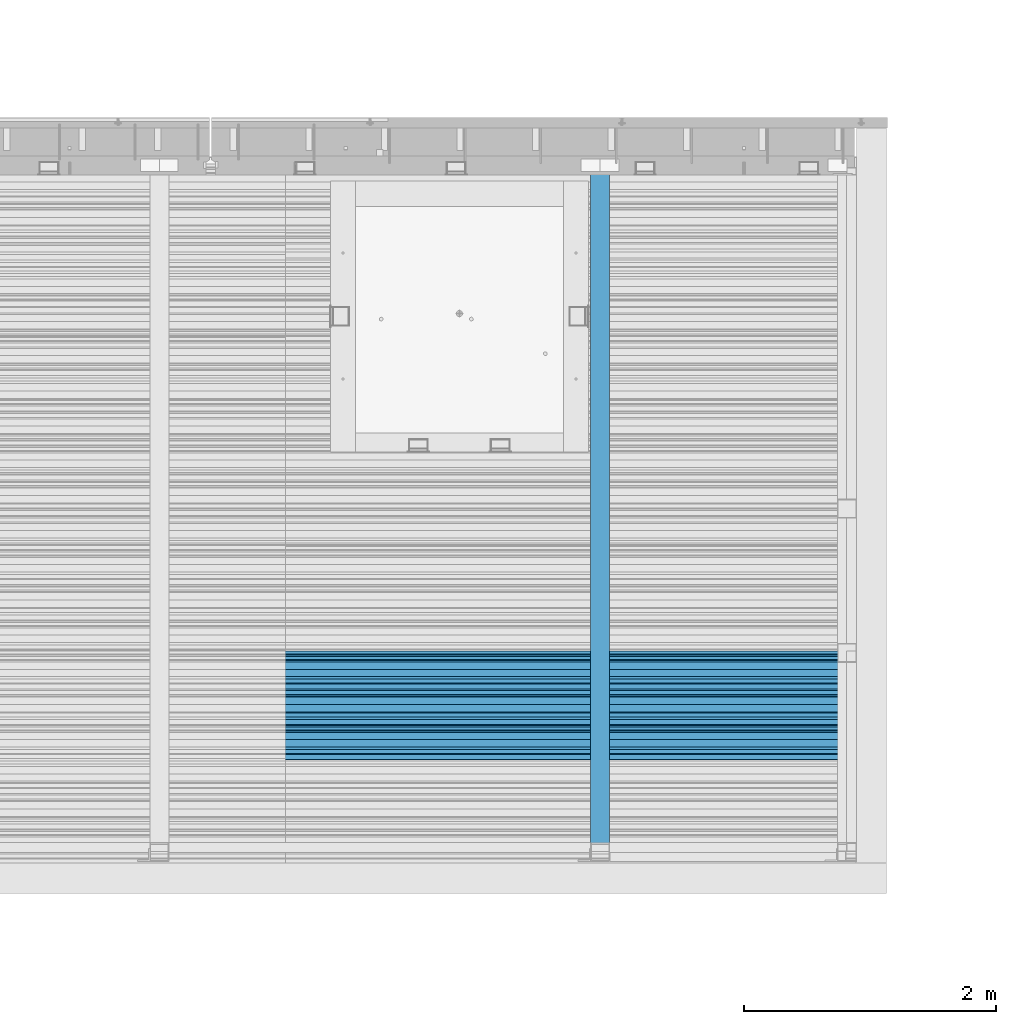
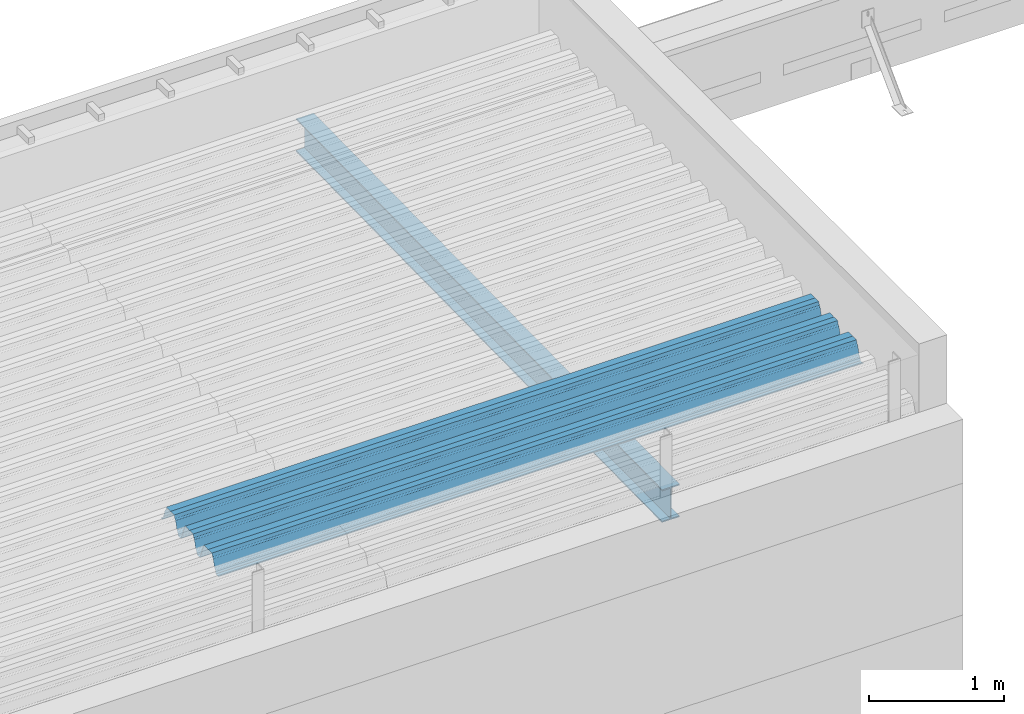
# One storey, part 37 of 153: 2 beams, 2 elements without a shape of their own.
"""IFC2X3 building model written with IfcOpenShell, lengths in millimetres."""

from ifc_helpers import new_model, si_unit, frame, origin_with_axes, place, context, subcontext, project, spatial, faceted_brep, material, type_object, element, aggregate, save


model = new_model("IFC2X3")

# Units and contexts
model_context = context("Model", 3, precision=1e-05, world=origin_with_axes())
body_context = subcontext(model_context, "Body", "Model", "MODEL_VIEW")
ifc_project = project(units=[si_unit("LENGTHUNIT", "METRE", prefix="MILLI"), si_unit("AREAUNIT", "SQUARE_METRE"), si_unit("VOLUMEUNIT", "CUBIC_METRE"), si_unit("MASSUNIT", "GRAM", prefix="KILO"), si_unit("TIMEUNIT", "SECOND"), si_unit("PLANEANGLEUNIT", "RADIAN"), si_unit("SOLIDANGLEUNIT", "STERADIAN"), si_unit("THERMODYNAMICTEMPERATUREUNIT", "DEGREE_CELSIUS"), si_unit("LUMINOUSINTENSITYUNIT", "LUMEN")], contexts=[model_context])

# Site, building, storey
site_placement = place(None, origin_with_axes())
site = spatial("IfcSite", under=ifc_project, at=site_placement, CompositionType="ELEMENT")
building_placement = place(site_placement, origin_with_axes())
building = spatial("IfcBuilding", under=site, at=building_placement, CompositionType="ELEMENT")
storey_placement = place(building_placement, origin_with_axes())
storey = spatial("IfcBuildingStorey", under=building, at=storey_placement, Name="8", CompositionType="ELEMENT", Elevation=0.0)

# Assembly, beam
assembly_1_placement = place(storey_placement, origin_with_axes())
assembly_1 = element("IfcElementAssembly", 1, at=assembly_1_placement, inside=storey, Name="Steel Assembly", AssemblyPlace="NOTDEFINED", PredefinedType="RIGID_FRAME")
ifc_material = material(Name="STEEL/S355J2")
beam_type_1 = type_object("IfcBeamType", Name="IPE300", PredefinedType="NOTDEFINED")
beam_1_placement = place(assembly_1_placement, frame((19752.0, 15128.0908589909, 105518.668698015), z_axis=(0.0, -0.0124990270013869, 0.999921884110963), x_axis=(0.0, 0.999921884110963, 0.0124990270013883)))
beam_1 = element("IfcBeam", 2, at=beam_1_placement, type_object=beam_type_1, material=ifc_material, ObjectType="IPE300", context=body_context, shape_type="Brep", body=[
    faceted_brep([(3.63797880709171e-12, 75.0, -149.999999999985), (0.0, 75.0, -139.300000189993), (5440.87494889885, 75.0, -139.300000189993), (5440.87494889886, 75.0, -150.0), (0.0, 3.5499999525, -139.300000189993), (5440.87494889885, 3.5499999525, -139.300000189993), (0.0, 3.5499999525, 139.300000190022), (5440.87494889885, 3.5499999525, 139.300000190022), (0.0, 75.0, 139.300000190022), (5440.87494889885, 75.0, 139.300000190022), (3.63797880709171e-12, 75.0, 150.0), (5440.87494889885, 75.0, 150.0), (3.63797880709171e-12, -75.0, 150.0), (5440.87494889885, -75.0, 150.0), (0.0, -75.0, 139.300000190022), (5440.87494889885, -75.0, 139.300000190022), (0.0, -3.5499999525, 139.300000190022), (5440.87494889885, -3.5499999525, 139.300000190022), (0.0, -3.5499999525, -139.300000189993), (5440.87494889885, -3.5499999525, -139.300000189993), (0.0, -75.0, -139.300000189993), (5440.87494889885, -75.0, -139.300000189993), (3.63797880709171e-12, -75.0, -149.999999999985), (5440.87494889886, -75.0, -150.0)], [[[0, 1, 2, 3]], [[1, 4, 5, 2]], [[4, 6, 7, 5]], [[6, 8, 9, 7]], [[8, 10, 11, 9]], [[10, 12, 13, 11]], [[12, 14, 15, 13]], [[14, 16, 17, 15]], [[16, 18, 19, 17]], [[18, 20, 21, 19]], [[20, 22, 23, 21]], [[22, 0, 3, 23]], [[5, 7, 9, 11, 13, 15, 17, 19, 21, 23, 3, 2]], [[22, 20, 18, 16, 14, 12, 10, 8, 6, 4, 1, 0]]]),
])
aggregate(assembly_1, [beam_1])

assembly_2_placement = place(storey_placement, origin_with_axes())
assembly_2 = element("IfcElementAssembly", 3, at=assembly_2_placement, inside=storey, Name="Steel Assembly", AssemblyPlace="NOTDEFINED", PredefinedType="RIGID_FRAME")
beam_type_2 = type_object("IfcBeamType", Name="W", PredefinedType="NOTDEFINED")
beam_2_placement = place(assembly_2_placement, frame((21782.0, 16215.1442180648, 105760.274680667), z_axis=(0.0, -0.0124990270013869, 0.999921884110963), x_axis=(-1.0, 3.00000001838171e-08, 0.0)))
beam_2 = element("IfcBeam", 4, at=beam_2_placement, type_object=beam_type_2, material=ifc_material, ObjectType="W", context=body_context, shape_type="Brep", body=[
    faceted_brep([(0.0, -412.839996337891, -77.0100021362159), (0.0, -409.160003662109, -77.0100021362014), (5530.0, -409.160003662109, -77.0100021362014), (5530.0, -412.839996337891, -77.0100021362159), (0.0, -408.070007324222, -73.4800033569045), (5530.0, -408.070007324222, -73.4800033569045), (0.0, -400.339996337894, -48.0600013732619), (5530.0, -400.339996337894, -48.0600013732619), (0.0, -399.459991455082, -46.5600013732619), (5530.0, -399.459991455082, -46.5600013732619), (0.0, -390.329986572269, -36.5499992370314), (5530.0, -390.329986572269, -36.5499992370314), (0.0, -389.19000244141, -34.6300010680861), (5530.0, -389.19000244141, -34.6300010680861), (0.0, -367.820007324222, 35.3400001526024), (5530.0, -367.820007324222, 35.3400001526024), (0.0, -366.989990234379, 36.8499984741502), (5530.0, -366.989990234379, 36.8499984741502), (0.0, -357.809997558597, 46.8600006103807), (5530.0, -357.809997558597, 46.8600006103807), (0.0, -356.720001220707, 48.7700004577782), (5530.0, -356.720001220707, 48.7700004577782), (0.0, -349.309997558594, 73.1500015258935), (5530.0, -349.309997558594, 73.1500015258935), (0.0, -347.850006103516, 75.2300033569481), (5530.0, -347.850006103516, 75.2300033569481), (0.0, -345.470001220707, 76.010002136245), (5530.0, -345.470001220707, 76.010002136245), (0.0, -305.480010986332, 76.010002136245), (5530.0, -305.480010986332, 76.010002136245), (0.0, -304.279998779301, 75.8000030517578), (5530.0, -304.279998779301, 75.8000030517578), (0.0, -291.679992675785, 71.6999969482567), (5530.0, -291.679992675785, 71.6999969482567), (0.0, -290.179992675789, 71.2300033569481), (5530.0, -290.179992675789, 71.2300033569481), (0.0, -288.720001220707, 71.6999969482567), (5530.0, -288.720001220707, 71.6999969482567), (0.0, -276.119995117191, 75.8000030517869), (5530.0, -276.119995117191, 75.8000030517869), (0.0, -274.929992675785, 76.010002136245), (5530.0, -274.929992675785, 76.010002136245), (0.0, -234.94000244141, 76.010002136245), (5530.0, -234.94000244141, 76.010002136245), (0.0, -232.550003051758, 75.2300033569627), (5530.0, -232.550003051758, 75.2300033569627), (0.0, -231.100006103519, 73.1500015258935), (5530.0, -231.100006103519, 73.1500015258935), (0.0, -223.679992675785, 48.7700004577782), (5530.0, -223.679992675785, 48.7700004577782), (0.0, -222.589996337894, 46.8600006103661), (5530.0, -222.589996337894, 46.8600006103661), (0.0, -213.410003662113, 36.8499984741502), (5530.0, -213.410003662113, 36.8499984741502), (0.0, -212.529998779301, 35.3400001526024), (5530.0, -212.529998779301, 35.3400001526024), (0.0, -191.160003662109, -34.6300010681007), (5530.0, -191.160003662109, -34.6300010681007), (0.0, -190.070007324222, -36.5499992370605), (5530.0, -190.070007324222, -36.5499992370605), (0.0, -180.940002441406, -46.560001373291), (5530.0, -180.940002441406, -46.560001373291), (0.0, -180.059997558597, -48.0600013732619), (5530.0, -180.059997558597, -48.0600013732619), (0.0, -172.330001831055, -73.480003356919), (5530.0, -172.330001831055, -73.480003356919), (0.0, -171.240005493168, -77.0100021362159), (5530.0, -171.240005493168, -77.0100021362159), (0.0, -129.330001831062, -77.0100021362014), (5530.0, -129.330001831062, -77.0100021362014), (0.0, -128.300003051761, -73.480003356919), (5530.0, -128.300003051761, -73.480003356919), (0.0, -120.51999664307, -48.0600013732765), (5530.0, -120.51999664307, -48.0600013732765), (0.0, -119.629997253418, -46.5600013732765), (5530.0, -119.629997253418, -46.5600013732765), (0.0, -110.500000000004, -36.5499992370314), (5530.0, -110.500000000004, -36.5499992370314), (0.0, -109.419998168949, -34.6300010680861), (5530.0, -109.419998168949, -34.6300010680861), (0.0, -88.0500030517615, 35.3400001526024), (5530.0, -88.0500030517615, 35.3400001526024), (0.0, -87.160003662113, 36.8499984741356), (5530.0, -87.160003662113, 36.8499984741356), (0.0, -78.0400009155273, 46.8600006103807), (5530.0, -78.0400009155273, 46.8600006103807), (0.0, -76.8899993896557, 48.7700004577782), (5530.0, -76.8899993896557, 48.7700004577782), (0.0, -69.4800033569336, 73.1500015258935), (5530.0, -69.4800033569336, 73.1500015258935), (0.0, -68.0299987793042, 75.2300033569336), (5530.0, -68.0299987793042, 75.2300033569336), (0.0, -65.6399993896521, 76.010002136245), (5530.0, -65.6399993896521, 76.010002136245), (0.0, -25.6499996185375, 76.0100021362596), (5530.0, -25.6499996185375, 76.0100021362596), (0.0, -24.5100002288891, 75.8000030517724), (5530.0, -24.5100002288891, 75.8000030517724), (0.0, -11.8500003814697, 71.6999969482567), (5530.0, -11.8500003814697, 71.6999969482567), (0.0, -10.3999996185339, 71.2300033569481), (5530.0, -10.3999996185339, 71.2300033569481), (0.0, -8.89999961853391, 71.6999969482567), (5530.0, -8.89999961853391, 71.6999969482567), (0.0, 3.71000003814333, 75.8000030517724), (5530.0, 3.71000003814333, 75.8000030517724), (0.0, 4.90000009536379, 76.0100021362596), (5530.0, 4.90000009536379, 76.0100021362596), (0.0, 44.8899993896484, 76.010002136245), (5530.0, 44.8899993896484, 76.010002136245), (0.0, 47.2799987792932, 75.2300033569481), (5530.0, 47.2799987792932, 75.2300033569481), (0.0, 48.6800003051721, 73.1500015258935), (5530.0, 48.6800003051721, 73.1500015258935), (0.0, 56.1500015258753, 48.7700004577782), (5530.0, 56.1500015258753, 48.7700004577782), (0.0, 57.2400016784632, 46.8600006103807), (5530.0, 57.2400016784632, 46.8600006103807), (0.0, 66.3700027465784, 36.8499984741211), (5530.0, 66.3700027465784, 36.8499984741211), (0.0, 67.2499999999964, 35.3400001526024), (5530.0, 67.2499999999964, 35.3400001526024), (0.0, 88.6200027465748, -34.6300010681007), (5530.0, 88.6200027465748, -34.6300010681007), (0.0, 89.709999084469, -36.549999237046), (5530.0, 89.709999084469, -36.549999237046), (0.0, 98.8899993896412, -46.5600013732765), (5530.0, 98.8899993896412, -46.5600013732765), (0.0, 99.7699966430628, -48.0600013732765), (5530.0, 99.7699966430628, -48.0600013732765), (0.0, 107.499999999996, -73.4800033569336), (5530.0, 107.499999999996, -73.4800033569336), (0.0, 108.589996337887, -77.0100021362014), (5530.0, 108.589996337887, -77.0100021362014), (0.0, 112.269996643063, -77.0100021362159), (5530.0, 112.269996643063, -77.0100021362159), (0.0, 146.759994506836, -77.0100021362159), (5530.0, 146.759994506836, -77.0100021362159), (0.0, 150.440002441403, -77.0100021362159), (5530.0, 150.440002441403, -77.0100021362159), (0.0, 151.529998779297, -73.480003356919), (5530.0, 151.529998779297, -73.480003356919), (0.0, 159.30999755859, -48.0600013732765), (5530.0, 159.30999755859, -48.0600013732765), (0.0, 160.190002441406, -46.5600013732619), (5530.0, 160.190002441406, -46.5600013732619), (0.0, 169.320007324215, -36.549999237046), (5530.0, 169.320007324215, -36.549999237046), (0.0, 170.410003662106, -34.6300010680861), (5530.0, 170.410003662106, -34.6300010680861), (0.0, 191.779998779293, 35.3400001526024), (5530.0, 191.779998779293, 35.3400001526024), (0.0, 192.660003662109, 36.8499984741502), (5530.0, 192.660003662109, 36.8499984741502), (0.0, 201.789993286129, 46.8600006103661), (5530.0, 201.789993286129, 46.8600006103661), (0.0, 202.880004882809, 48.7700004577637), (5530.0, 202.880004882809, 48.7700004577637), (0.0, 210.350006103512, 73.150001525908), (5530.0, 210.350006103512, 73.150001525908), (0.0, 211.800003051754, 75.2300033569481), (5530.0, 211.800003051754, 75.2300033569481), (0.0, 214.190002441406, 76.010002136245), (5530.0, 214.190002441406, 76.010002136245), (0.0, 254.179992675778, 76.010002136245), (5530.0, 254.179992675778, 76.010002136245), (0.0, 255.320007324215, 75.8000030517869), (5530.0, 255.320007324215, 75.8000030517869), (0.0, 267.980010986324, 71.6999969482713), (5530.0, 267.980010986324, 71.6999969482713), (0.0, 269.429992675778, 71.2300033569481), (5530.0, 269.429992675778, 71.2300033569481), (0.0, 270.880004882809, 71.6999969482567), (5530.0, 270.880004882809, 71.6999969482567), (0.0, 283.540008544918, 75.8000030517869), (5530.0, 283.540008544918, 75.8000030517869), (0.0, 284.679992675778, 76.010002136245), (5530.0, 284.679992675778, 76.010002136245), (0.0, 324.670013427731, 76.010002136245), (5530.0, 324.670013427731, 76.010002136245), (0.0, 327.049987792969, 75.2300033569627), (5530.0, 327.049987792969, 75.2300033569627), (0.0, 328.510009765625, 73.1500015258789), (5530.0, 328.510009765625, 73.1500015258789), (0.0, 335.980010986324, 48.7700004577782), (5530.0, 335.980010986324, 48.7700004577782), (0.0, 337.05999755859, 46.8600006103661), (5530.0, 337.05999755859, 46.8600006103661), (0.0, 346.190002441399, 36.8499984741356), (5530.0, 346.190002441399, 36.8499984741356), (0.0, 347.079986572266, 35.3400001526024), (5530.0, 347.079986572266, 35.3400001526024), (0.0, 368.450012207028, -34.6300010680861), (5530.0, 368.450012207028, -34.6300010680861), (0.0, 369.529998779293, -36.5499992370314), (5530.0, 369.529998779293, -36.5499992370314), (0.0, 378.660003662106, -46.5600013732619), (5530.0, 378.660003662106, -46.5600013732619), (0.0, 379.540008544918, -48.0600013732619), (5530.0, 379.540008544918, -48.0600013732619), (0.0, 387.329986572262, -73.480003356919), (5530.0, 387.329986572262, -73.480003356919), (0.0, 388.410003662109, -77.0100021362159), (5530.0, 388.410003662109, -77.0100021362159), (0.0, 392.100006103512, -77.0100021362159), (5530.0, 392.100006103512, -77.0100021362159), (0.0, 426.589996337887, -77.0100021362159), (5530.0, 426.589996337887, -77.0100021362159), (0.0, 430.269989013668, -77.0100021362159), (5530.0, 430.269989013668, -77.0100021362159), (0.0, 431.359985351559, -73.4800033569045), (5530.0, 431.359985351559, -73.4800033569045), (0.0, 433.179992675778, -67.5699996948097), (5530.0, 433.179992675778, -67.5699996948097), (0.0, 432.220001220699, -67.2699966430373), (5530.0, 432.220001220699, -67.2699966430373), (0.0, 430.410003662106, -73.1800003051612), (5530.0, 430.410003662106, -73.1800003051612), (0.0, 429.529998779293, -76.0100021362159), (5530.0, 429.529998779293, -76.0100021362159), (0.0, 426.589996337891, -76.0100021362159), (5530.0, 426.589996337891, -76.0100021362159), (0.0, 392.100006103512, -76.0100021362159), (5530.0, 392.100006103512, -76.0100021362159), (0.0, 389.149993896481, -76.0100021362014), (5530.0, 389.149993896481, -76.0100021362014), (0.0, 388.279998779293, -73.1800003051467), (5530.0, 388.279998779293, -73.1800003051467), (0.0, 380.470001220699, -47.659999847383), (5530.0, 380.470001220699, -47.659999847383), (0.0, 379.470001220699, -45.9599990844436), (5530.0, 379.470001220699, -45.9599990844436), (0.0, 370.350006103512, -35.9599990844581), (5530.0, 370.350006103512, -35.9599990844581), (0.0, 369.369995117184, -34.2299995422218), (5530.0, 369.369995117184, -34.2299995422218), (0.0, 347.999999999996, 35.7500000000146), (5530.0, 347.999999999996, 35.7500000000146), (0.0, 346.999999999996, 37.4399986267235), (5530.0, 346.999999999996, 37.4399986267235), (0.0, 337.880004882809, 47.450000762954), (5530.0, 337.880004882809, 47.450000762954), (0.0, 336.899993896481, 49.1699981689453), (5530.0, 336.899993896481, 49.1699981689453), (0.0, 329.420013427731, 73.5999984741356), (5530.0, 329.420013427731, 73.5999984741356), (0.0, 327.679992675781, 76.0699996948533), (5530.0, 327.679992675781, 76.0699996948533), (0.0, 324.829986572262, 77.010002136245), (5530.0, 324.829986572262, 77.010002136245), (0.0, 284.589996337887, 77.010002136245), (5530.0, 284.589996337887, 77.010002136245), (0.0, 283.290008544922, 76.769996643081), (5530.0, 283.290008544922, 76.769996643081), (0.0, 270.570007324215, 72.6500015258935), (5530.0, 270.570007324215, 72.6500015258935), (0.0, 269.429992675781, 72.2799987793114), (5530.0, 269.429992675781, 72.2799987793114), (0.0, 268.279998779293, 72.650001525908), (5530.0, 268.279998779293, 72.650001525908), (0.0, 255.570007324219, 76.769996643081), (5530.0, 255.570007324219, 76.769996643081), (0.0, 254.270004272461, 77.0100021362596), (5530.0, 254.270004272461, 77.0100021362596), (0.0, 214.029998779293, 77.0100021362596), (5530.0, 214.029998779293, 77.0100021362596), (0.0, 211.179992675781, 76.0699996948388), (5530.0, 211.179992675781, 76.0699996948388), (0.0, 209.440002441403, 73.5999984741356), (5530.0, 209.440002441403, 73.5999984741356), (0.0, 201.960006713864, 49.1699981689599), (5530.0, 201.960006713864, 49.1699981689599), (0.0, 200.979995727532, 47.450000762954), (5530.0, 200.979995727532, 47.450000762954), (0.0, 191.850006103508, 37.4399986267235), (5530.0, 191.850006103508, 37.4399986267235), (0.0, 190.860000610352, 35.7500000000146), (5530.0, 190.860000610352, 35.7500000000146), (0.0, 169.49000549316, -34.2299995422218), (5530.0, 169.49000549316, -34.2299995422218), (0.0, 168.509994506832, -35.9599990844581), (5530.0, 168.509994506832, -35.9599990844581), (0.0, 159.380004882805, -45.9599990844436), (5530.0, 159.380004882805, -45.9599990844436), (0.0, 158.389999389645, -47.6599998473976), (5530.0, 158.389999389645, -47.6599998473976), (0.0, 150.580001831051, -73.1800003051612), (5530.0, 150.580001831051, -73.1800003051612), (0.0, 149.710006713864, -76.0100021362159), (5530.0, 149.710006713864, -76.0100021362159), (0.0, 146.759994506836, -76.0100021362159), (5530.0, 146.759994506836, -76.0100021362159), (0.0, 112.269996643063, -76.0100021362159), (5530.0, 112.269996643063, -76.0100021362159), (0.0, 109.319999694821, -76.0100021362159), (5530.0, 109.319999694821, -76.0100021362159), (0.0, 108.449996948239, -73.1900024413917), (5530.0, 108.449996948239, -73.1900024413917), (0.0, 100.690002441406, -47.659999847383), (5530.0, 100.690002441406, -47.659999847383), (0.0, 99.6999969482386, -45.9599990844581), (5530.0, 99.6999969482386, -45.9599990844581), (0.0, 90.5199966430664, -35.9599990844581), (5530.0, 90.5199966430664, -35.9599990844581), (0.0, 89.5400009155273, -34.2299995422218), (5530.0, 89.5400009155273, -34.2299995422218), (0.0, 68.1699981689417, 35.7500000000146), (5530.0, 68.1699981689417, 35.7500000000146), (0.0, 67.1699981689417, 37.4399986267235), (5530.0, 67.1699981689417, 37.4399986267235), (0.0, 58.0499992370569, 47.4500007629686), (5530.0, 58.0499992370569, 47.4500007629686), (0.0, 57.0699996948206, 49.1699981689599), (5530.0, 57.0699996948206, 49.1699981689599), (0.0, 49.5900001525843, 73.5899963379052), (5530.0, 49.5900001525843, 73.5899963379052), (0.0, 47.9099998474085, 76.0699996948388), (5530.0, 47.9099998474085, 76.0699996948388), (0.0, 45.0499992370569, 77.010002136245), (5530.0, 45.0499992370569, 77.010002136245), (0.0, 4.82000017165774, 77.010002136245), (5530.0, 4.82000017165774, 77.010002136245), (0.0, 3.47000002860659, 76.7699966430955), (5530.0, 3.47000002860659, 76.7699966430955), (0.0, -9.19999980926514, 72.6500015258935), (5530.0, -9.19999980926514, 72.6500015258935), (0.0, -10.3900003433264, 72.2799987792969), (5530.0, -10.3900003433264, 72.2799987792969), (0.0, -11.5399999618567, 72.6500015258935), (5530.0, -11.5399999618567, 72.6500015258935), (0.0, -24.2600002288855, 76.769996643081), (5530.0, -24.2600002288855, 76.769996643081), (0.0, -25.559999465946, 77.0100021362596), (5530.0, -25.559999465946, 77.0100021362596), (0.0, -65.8000030517615, 77.0100021362596), (5530.0, -65.8000030517615, 77.0100021362596), (0.0, -68.6500015258862, 76.0699996948533), (5530.0, -68.6500015258862, 76.0699996948533), (0.0, -70.3899993896521, 73.5999984741356), (5530.0, -70.3899993896521, 73.5999984741356), (0.0, -77.8199996948242, 49.1800003051903), (5530.0, -77.8199996948242, 49.1800003051903), (0.0, -78.8399963378943, 47.450000762954), (5530.0, -78.8399963378943, 47.450000762954), (0.0, -87.9700012207031, 37.4399986267235), (5530.0, -87.9700012207031, 37.4399986267235), (0.0, -88.9700012207068, 35.7500000000146), (5530.0, -88.9700012207068, 35.7500000000146), (0.0, -110.339996337894, -34.2299995422218), (5530.0, -110.339996337894, -34.2299995422218), (0.0, -111.319999694828, -35.9599990844581), (5530.0, -111.319999694828, -35.9599990844581), (0.0, -120.440002441406, -45.9599990844436), (5530.0, -120.440002441406, -45.9599990844436), (0.0, -121.44000244141, -47.6599998473976), (5530.0, -121.44000244141, -47.6599998473976), (0.0, -129.250000000004, -73.1900024413771), (5530.0, -129.250000000004, -73.1900024413771), (0.0, -130.080001831062, -76.0100021362159), (5530.0, -130.080001831062, -76.0100021362159), (0.0, -170.5, -76.0100021362014), (5530.0, -170.5, -76.0100021362014), (0.0, -171.380004882816, -73.1900024413917), (5530.0, -171.380004882816, -73.1900024413917), (0.0, -179.139999389652, -47.6599998473976), (5530.0, -179.139999389652, -47.6599998473976), (0.0, -180.130004882816, -45.9599990844581), (5530.0, -180.130004882816, -45.9599990844581), (0.0, -189.259994506836, -35.9599990844581), (5530.0, -189.259994506836, -35.9599990844581), (0.0, -190.240005493168, -34.2299995422218), (5530.0, -190.240005493168, -34.2299995422218), (0.0, -211.610000610355, 35.7500000000146), (5530.0, -211.610000610355, 35.7500000000146), (0.0, -212.600006103519, 37.4399986267381), (5530.0, -212.600006103519, 37.4399986267381), (0.0, -221.779998779301, 47.450000762954), (5530.0, -221.779998779301, 47.450000762954), (0.0, -222.75999450684, 49.1699981689599), (5530.0, -222.75999450684, 49.1699981689599), (0.0, -230.190002441406, 73.5999984741356), (5530.0, -230.190002441406, 73.5999984741356), (0.0, -231.919998168945, 76.0699996948388), (5530.0, -231.919998168945, 76.0699996948388), (0.0, -234.779998779301, 77.010002136245), (5530.0, -234.779998779301, 77.010002136245), (0.0, -275.010009765629, 77.010002136245), (5530.0, -275.010009765629, 77.010002136245), (0.0, -276.359985351563, 76.769996643081), (5530.0, -276.359985351563, 76.769996643081), (0.0, -289.029998779297, 72.6500015258789), (5530.0, -289.029998779297, 72.6500015258789), (0.0, -290.179992675785, 72.2799987793114), (5530.0, -290.179992675785, 72.2799987793114), (0.0, -291.380004882816, 72.650001525908), (5530.0, -291.380004882816, 72.650001525908), (0.0, -304.040008544926, 76.769996643081), (5530.0, -304.040008544926, 76.769996643081), (0.0, -305.390014648441, 77.010002136245), (5530.0, -305.390014648441, 77.010002136245), (0.0, -345.63000488282, 77.0100021362596), (5530.0, -345.63000488282, 77.0100021362596), (0.0, -348.480010986332, 76.0699996948388), (5530.0, -348.480010986332, 76.0699996948388), (0.0, -350.220001220707, 73.5999984741356), (5530.0, -350.220001220707, 73.5999984741356), (0.0, -357.649993896492, 49.1699981689599), (5530.0, -357.649993896492, 49.1699981689599), (0.0, -358.63000488282, 47.450000762954), (5530.0, -358.63000488282, 47.450000762954), (0.0, -367.809997558594, 37.4300003051903), (5530.0, -367.809997558594, 37.4300003051903), (0.0, -368.750000000004, 35.7299995422654), (5530.0, -368.750000000004, 35.7299995422654), (0.0, -390.109985351566, -34.2200012207031), (5530.0, -390.109985351566, -34.2200012207031), (0.0, -391.140014648441, -35.9500007629249), (5530.0, -391.140014648441, -35.9500007629249), (0.0, -400.269989013676, -45.9599990844436), (5530.0, -400.269989013676, -45.9599990844436), (0.0, -401.269989013672, -47.6599998473976), (5530.0, -401.269989013672, -47.6599998473976), (0.0, -409.029998779297, -73.1900024413917), (5530.0, -409.029998779297, -73.1900024413917), (0.0, -409.899993896488, -76.0100021362159), (5530.0, -409.899993896488, -76.0100021362159), (0.0, -412.839996337891, -76.0100021362159), (5530.0, -412.839996337891, -76.0100021362159), (0.0, -433.179992675785, -76.0100021362159), (5530.0, -433.179992675785, -76.0100021362159), (0.0, -433.179992675785, -77.0100021362159), (5530.0, -433.179992675785, -77.0100021362159)], [[[0, 1, 2, 3]], [[1, 4, 5, 2]], [[4, 6, 7, 5]], [[6, 8, 9, 7]], [[8, 10, 11, 9]], [[10, 12, 13, 11]], [[12, 14, 15, 13]], [[14, 16, 17, 15]], [[16, 18, 19, 17]], [[18, 20, 21, 19]], [[20, 22, 23, 21]], [[22, 24, 25, 23]], [[24, 26, 27, 25]], [[26, 28, 29, 27]], [[28, 30, 31, 29]], [[30, 32, 33, 31]], [[32, 34, 35, 33]], [[34, 36, 37, 35]], [[36, 38, 39, 37]], [[38, 40, 41, 39]], [[40, 42, 43, 41]], [[42, 44, 45, 43]], [[44, 46, 47, 45]], [[46, 48, 49, 47]], [[48, 50, 51, 49]], [[50, 52, 53, 51]], [[52, 54, 55, 53]], [[54, 56, 57, 55]], [[56, 58, 59, 57]], [[58, 60, 61, 59]], [[60, 62, 63, 61]], [[62, 64, 65, 63]], [[64, 66, 67, 65]], [[66, 68, 69, 67]], [[68, 70, 71, 69]], [[70, 72, 73, 71]], [[72, 74, 75, 73]], [[74, 76, 77, 75]], [[76, 78, 79, 77]], [[78, 80, 81, 79]], [[80, 82, 83, 81]], [[82, 84, 85, 83]], [[84, 86, 87, 85]], [[86, 88, 89, 87]], [[88, 90, 91, 89]], [[90, 92, 93, 91]], [[92, 94, 95, 93]], [[94, 96, 97, 95]], [[96, 98, 99, 97]], [[98, 100, 101, 99]], [[100, 102, 103, 101]], [[102, 104, 105, 103]], [[104, 106, 107, 105]], [[106, 108, 109, 107]], [[108, 110, 111, 109]], [[110, 112, 113, 111]], [[112, 114, 115, 113]], [[114, 116, 117, 115]], [[116, 118, 119, 117]], [[118, 120, 121, 119]], [[120, 122, 123, 121]], [[122, 124, 125, 123]], [[124, 126, 127, 125]], [[126, 128, 129, 127]], [[128, 130, 131, 129]], [[130, 132, 133, 131]], [[132, 134, 135, 133]], [[134, 136, 137, 135]], [[136, 138, 139, 137]], [[138, 140, 141, 139]], [[140, 142, 143, 141]], [[142, 144, 145, 143]], [[144, 146, 147, 145]], [[146, 148, 149, 147]], [[148, 150, 151, 149]], [[150, 152, 153, 151]], [[152, 154, 155, 153]], [[154, 156, 157, 155]], [[156, 158, 159, 157]], [[158, 160, 161, 159]], [[160, 162, 163, 161]], [[162, 164, 165, 163]], [[164, 166, 167, 165]], [[166, 168, 169, 167]], [[168, 170, 171, 169]], [[170, 172, 173, 171]], [[172, 174, 175, 173]], [[174, 176, 177, 175]], [[176, 178, 179, 177]], [[178, 180, 181, 179]], [[180, 182, 183, 181]], [[182, 184, 185, 183]], [[184, 186, 187, 185]], [[186, 188, 189, 187]], [[188, 190, 191, 189]], [[190, 192, 193, 191]], [[192, 194, 195, 193]], [[194, 196, 197, 195]], [[196, 198, 199, 197]], [[198, 200, 201, 199]], [[200, 202, 203, 201]], [[202, 204, 205, 203]], [[204, 206, 207, 205]], [[206, 208, 209, 207]], [[208, 210, 211, 209]], [[210, 212, 213, 211]], [[212, 214, 215, 213]], [[214, 216, 217, 215]], [[216, 218, 219, 217]], [[218, 220, 221, 219]], [[220, 222, 223, 221]], [[222, 224, 225, 223]], [[224, 226, 227, 225]], [[226, 228, 229, 227]], [[228, 230, 231, 229]], [[230, 232, 233, 231]], [[232, 234, 235, 233]], [[234, 236, 237, 235]], [[236, 238, 239, 237]], [[238, 240, 241, 239]], [[240, 242, 243, 241]], [[242, 244, 245, 243]], [[244, 246, 247, 245]], [[246, 248, 249, 247]], [[248, 250, 251, 249]], [[250, 252, 253, 251]], [[252, 254, 255, 253]], [[254, 256, 257, 255]], [[256, 258, 259, 257]], [[258, 260, 261, 259]], [[260, 262, 263, 261]], [[262, 264, 265, 263]], [[264, 266, 267, 265]], [[266, 268, 269, 267]], [[268, 270, 271, 269]], [[270, 272, 273, 271]], [[272, 274, 275, 273]], [[274, 276, 277, 275]], [[276, 278, 279, 277]], [[278, 280, 281, 279]], [[280, 282, 283, 281]], [[282, 284, 285, 283]], [[284, 286, 287, 285]], [[286, 288, 289, 287]], [[288, 290, 291, 289]], [[290, 292, 293, 291]], [[292, 294, 295, 293]], [[294, 296, 297, 295]], [[296, 298, 299, 297]], [[298, 300, 301, 299]], [[300, 302, 303, 301]], [[302, 304, 305, 303]], [[304, 306, 307, 305]], [[306, 308, 309, 307]], [[308, 310, 311, 309]], [[310, 312, 313, 311]], [[312, 314, 315, 313]], [[314, 316, 317, 315]], [[316, 318, 319, 317]], [[318, 320, 321, 319]], [[320, 322, 323, 321]], [[322, 324, 325, 323]], [[324, 326, 327, 325]], [[326, 328, 329, 327]], [[328, 330, 331, 329]], [[330, 332, 333, 331]], [[332, 334, 335, 333]], [[334, 336, 337, 335]], [[336, 338, 339, 337]], [[338, 340, 341, 339]], [[340, 342, 343, 341]], [[342, 344, 345, 343]], [[344, 346, 347, 345]], [[346, 348, 349, 347]], [[348, 350, 351, 349]], [[350, 352, 353, 351]], [[352, 354, 355, 353]], [[354, 356, 357, 355]], [[356, 358, 359, 357]], [[358, 360, 361, 359]], [[360, 362, 363, 361]], [[362, 364, 365, 363]], [[364, 366, 367, 365]], [[366, 368, 369, 367]], [[368, 370, 371, 369]], [[370, 372, 373, 371]], [[372, 374, 375, 373]], [[374, 376, 377, 375]], [[376, 378, 379, 377]], [[378, 380, 381, 379]], [[380, 382, 383, 381]], [[382, 384, 385, 383]], [[384, 386, 387, 385]], [[386, 388, 389, 387]], [[388, 390, 391, 389]], [[390, 392, 393, 391]], [[392, 394, 395, 393]], [[394, 396, 397, 395]], [[396, 398, 399, 397]], [[398, 400, 401, 399]], [[400, 402, 403, 401]], [[402, 404, 405, 403]], [[404, 406, 407, 405]], [[406, 408, 409, 407]], [[408, 410, 411, 409]], [[410, 412, 413, 411]], [[412, 414, 415, 413]], [[414, 416, 417, 415]], [[416, 418, 419, 417]], [[418, 420, 421, 419]], [[420, 422, 423, 421]], [[422, 424, 425, 423]], [[424, 426, 427, 425]], [[426, 428, 429, 427]], [[428, 430, 431, 429]], [[430, 0, 3, 431]], [[5, 7, 9, 11, 13, 15, 17, 19, 21, 23, 25, 27, 29, 31, 33, 35, 37, 39, 41, 43, 45, 47, 49, 51, 53, 55, 57, 59, 61, 63, 65, 67, 69, 71, 73, 75, 77, 79, 81, 83, 85, 87, 89, 91, 93, 95, 97, 99, 101, 103, 105, 107, 109, 111, 113, 115, 117, 119, 121, 123, 125, 127, 129, 131, 133, 135, 137, 139, 141, 143, 145, 147, 149, 151, 153, 155, 157, 159, 161, 163, 165, 167, 169, 171, 173, 175, 177, 179, 181, 183, 185, 187, 189, 191, 193, 195, 197, 199, 201, 203, 205, 207, 209, 211, 213, 215, 217, 219, 221, 223, 225, 227, 229, 231, 233, 235, 237, 239, 241, 243, 245, 247, 249, 251, 253, 255, 257, 259, 261, 263, 265, 267, 269, 271, 273, 275, 277, 279, 281, 283, 285, 287, 289, 291, 293, 295, 297, 299, 301, 303, 305, 307, 309, 311, 313, 315, 317, 319, 321, 323, 325, 327, 329, 331, 333, 335, 337, 339, 341, 343, 345, 347, 349, 351, 353, 355, 357, 359, 361, 363, 365, 367, 369, 371, 373, 375, 377, 379, 381, 383, 385, 387, 389, 391, 393, 395, 397, 399, 401, 403, 405, 407, 409, 411, 413, 415, 417, 419, 421, 423, 425, 427, 429, 431, 3, 2]], [[430, 428, 426, 424, 422, 420, 418, 416, 414, 412, 410, 408, 406, 404, 402, 400, 398, 396, 394, 392, 390, 388, 386, 384, 382, 380, 378, 376, 374, 372, 370, 368, 366, 364, 362, 360, 358, 356, 354, 352, 350, 348, 346, 344, 342, 340, 338, 336, 334, 332, 330, 328, 326, 324, 322, 320, 318, 316, 314, 312, 310, 308, 306, 304, 302, 300, 298, 296, 294, 292, 290, 288, 286, 284, 282, 280, 278, 276, 274, 272, 270, 268, 266, 264, 262, 260, 258, 256, 254, 252, 250, 248, 246, 244, 242, 240, 238, 236, 234, 232, 230, 228, 226, 224, 222, 220, 218, 216, 214, 212, 210, 208, 206, 204, 202, 200, 198, 196, 194, 192, 190, 188, 186, 184, 182, 180, 178, 176, 174, 172, 170, 168, 166, 164, 162, 160, 158, 156, 154, 152, 150, 148, 146, 144, 142, 140, 138, 136, 134, 132, 130, 128, 126, 124, 122, 120, 118, 116, 114, 112, 110, 108, 106, 104, 102, 100, 98, 96, 94, 92, 90, 88, 86, 84, 82, 80, 78, 76, 74, 72, 70, 68, 66, 64, 62, 60, 58, 56, 54, 52, 50, 48, 46, 44, 42, 40, 38, 36, 34, 32, 30, 28, 26, 24, 22, 20, 18, 16, 14, 12, 10, 8, 6, 4, 1, 0]]]),
])
aggregate(assembly_2, [beam_2])

save(model, "model.ifc")
